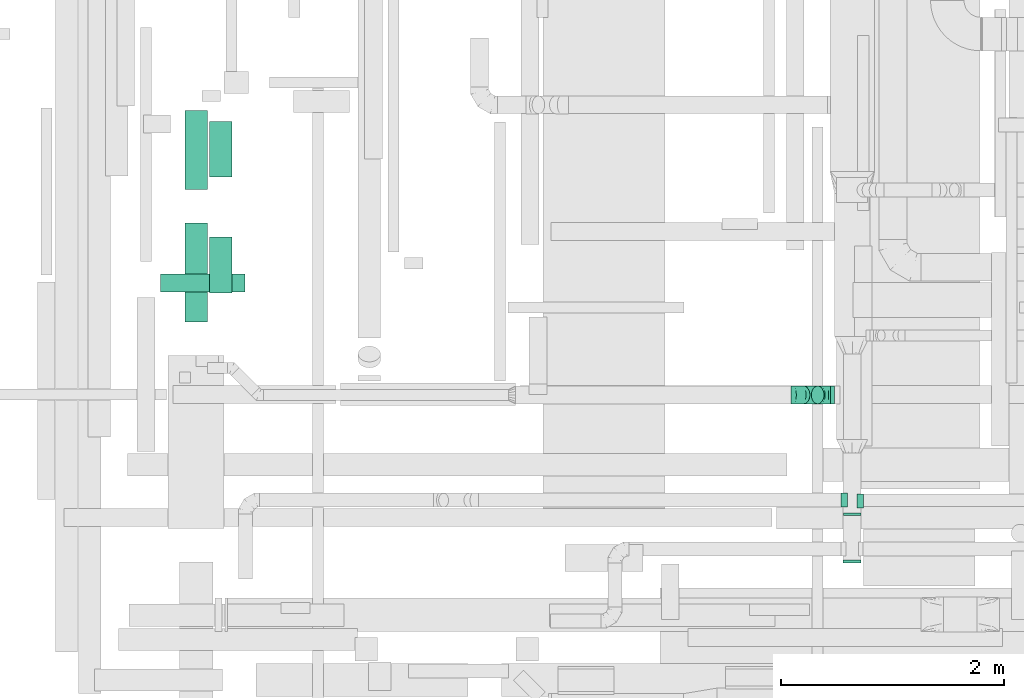
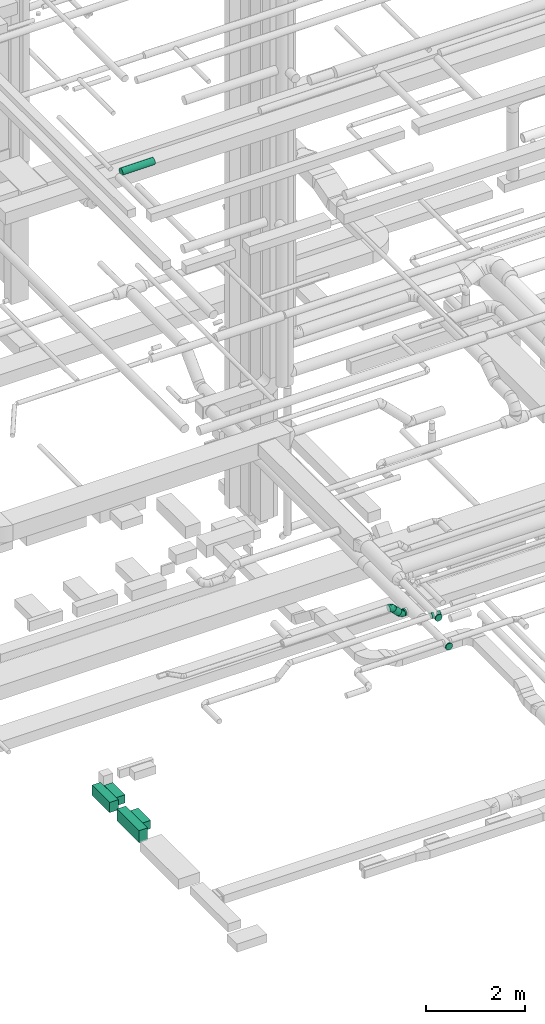
# One storey, part 117 of 337: 7 flow segments, 6 flow fittings.
"""IFC2X3 building model written with IfcOpenShell, lengths in millimetres."""

from ifc_helpers import new_model, entity, si_unit, converted_unit, derived_unit, direction, frame, origin, origin_2d_with_axis, place, context, subcontext, project, spatial, rectangle, circle, extrude, faceted_brep, source, transform, mapped, material, type_object, type_shapes, element, save


model = new_model("IFC2X3")

# Units and contexts
model_context = context("Model", 3, precision=0.01, world=origin(), true_north=direction((6.12303176911189e-17, 1.0)))
body_context = subcontext(model_context, "Body", "Model", "MODEL_VIEW")
ifc_project = project(units=[si_unit("LENGTHUNIT", "METRE", prefix="MILLI"), si_unit("AREAUNIT", "SQUARE_METRE"), si_unit("VOLUMEUNIT", "CUBIC_METRE"), converted_unit("PLANEANGLEUNIT", "DEGREE", entity("IfcRatioMeasure", 0.0174532925199433), si_unit("PLANEANGLEUNIT", "RADIAN"), dimensions=[0, 0, 0, 0, 0, 0, 0]), si_unit("MASSUNIT", "GRAM", prefix="KILO"), derived_unit("MASSDENSITYUNIT", [(si_unit("MASSUNIT", "GRAM", prefix="KILO"), 1), (si_unit("LENGTHUNIT", "METRE"), -3)]), derived_unit("MOMENTOFINERTIAUNIT", [(si_unit("LENGTHUNIT", "METRE"), 4)]), si_unit("TIMEUNIT", "SECOND"), si_unit("FREQUENCYUNIT", "HERTZ"), si_unit("THERMODYNAMICTEMPERATUREUNIT", "DEGREE_CELSIUS"), derived_unit("THERMALTRANSMITTANCEUNIT", [(si_unit("MASSUNIT", "GRAM", prefix="KILO"), 1), (si_unit("THERMODYNAMICTEMPERATUREUNIT", "KELVIN"), -1), (si_unit("TIMEUNIT", "SECOND"), -3)]), derived_unit("VOLUMETRICFLOWRATEUNIT", [(si_unit("LENGTHUNIT", "METRE"), 3), (si_unit("TIMEUNIT", "SECOND"), -1)]), derived_unit("MASSFLOWRATEUNIT", [(si_unit("MASSUNIT", "GRAM", prefix="KILO"), 1), (si_unit("TIMEUNIT", "SECOND"), -1)]), derived_unit("ROTATIONALFREQUENCYUNIT", [(si_unit("TIMEUNIT", "SECOND"), -1)]), si_unit("ELECTRICCURRENTUNIT", "AMPERE"), si_unit("ELECTRICVOLTAGEUNIT", "VOLT"), si_unit("POWERUNIT", "WATT"), si_unit("FORCEUNIT", "NEWTON", prefix="KILO"), si_unit("ILLUMINANCEUNIT", "LUX"), si_unit("LUMINOUSFLUXUNIT", "LUMEN"), si_unit("LUMINOUSINTENSITYUNIT", "CANDELA"), derived_unit("USERDEFINED", [(si_unit("MASSUNIT", "GRAM", prefix="KILO"), -1), (si_unit("LENGTHUNIT", "METRE"), -2), (si_unit("TIMEUNIT", "SECOND"), 3), (si_unit("LUMINOUSFLUXUNIT", "LUMEN"), 1)]), derived_unit("LINEARVELOCITYUNIT", [(si_unit("LENGTHUNIT", "METRE"), 1), (si_unit("TIMEUNIT", "SECOND"), -1)]), si_unit("PRESSUREUNIT", "PASCAL"), derived_unit("USERDEFINED", [(si_unit("LENGTHUNIT", "METRE"), -2), (si_unit("MASSUNIT", "GRAM", prefix="KILO"), 1), (si_unit("TIMEUNIT", "SECOND"), -2)]), derived_unit("LINEARFORCEUNIT", [(si_unit("MASSUNIT", "GRAM", prefix="KILO"), 1), (si_unit("LENGTHUNIT", "METRE"), 1), (si_unit("TIMEUNIT", "SECOND"), -2), (si_unit("LENGTHUNIT", "METRE"), -1)]), derived_unit("PLANARFORCEUNIT", [(si_unit("MASSUNIT", "GRAM", prefix="KILO"), 1), (si_unit("LENGTHUNIT", "METRE"), 1), (si_unit("TIMEUNIT", "SECOND"), -2), (si_unit("LENGTHUNIT", "METRE"), -2)])], contexts=[model_context])

# Site, building, storey
site_placement = place(None, origin())
site = spatial("IfcSite", under=ifc_project, at=site_placement, CompositionType="ELEMENT")
building_placement = place(site_placement, origin())
building = spatial("IfcBuilding", under=site, at=building_placement, CompositionType="ELEMENT")
storey_placement = place(building_placement, origin())
storey = spatial("IfcBuildingStorey", under=building, at=storey_placement, CompositionType="ELEMENT", Elevation=0.0)

# Flow segments
duct_segment_type_1 = type_object("IfcDuctSegmentType", PredefinedType="NOTDEFINED")
flow_segment_1_placement = place(storey_placement, frame((23644.4, 5216.02, -1025.0)))
element("IfcFlowSegment", 1, at=flow_segment_1_placement, inside=storey, type_object=duct_segment_type_1, context=body_context, shape_type="SweptSolid", body=[
    extrude(rectangle(XDim=709.508080000037, YDim=200.000000000002, at=origin_2d_with_axis()), frame((100.0, 354.75, 0.0), z_axis=(0.0, 0.0, 1.0), x_axis=(0.0, 1.0, 0.0)), (0.0, 0.0, 1.0), 250.0),
])
flow_segment_2_placement = place(storey_placement, frame((23644.4, 4031.28, -1050.0)))
element("IfcFlowSegment", 2, at=flow_segment_2_placement, inside=storey, type_object=duct_segment_type_1, context=body_context, shape_type="SweptSolid", body=[
    extrude(rectangle(XDim=884.746174604839, YDim=200.000000000002, at=origin_2d_with_axis()), frame((100.0, 442.37, 0.0), z_axis=(0.0, 0.0, 1.0), x_axis=(0.0, 1.0, 0.0)), (0.0, 0.0, 1.0), 300.0),
])
flow_segment_3_placement = place(storey_placement, frame((23864.4, 4290.43, -1000.0)))
element("IfcFlowSegment", 3, at=flow_segment_3_placement, inside=storey, type_object=duct_segment_type_1, context=body_context, shape_type="SweptSolid", body=[
    extrude(rectangle(XDim=199.999999999924, YDim=500.0, at=origin_2d_with_axis()), frame((100.0, 250.0, 0.0)), (0.0, 0.0, 1.0), 200.0),
])
flow_segment_4_placement = place(storey_placement, frame((23864.4, 5327.01, -1000.0)))
element("IfcFlowSegment", 4, at=flow_segment_4_placement, inside=storey, type_object=duct_segment_type_1, context=body_context, shape_type="SweptSolid", body=[
    extrude(rectangle(XDim=200.000000000002, YDim=500.0, at=origin_2d_with_axis()), frame((100.0, 250.0, 0.0)), (0.0, 0.0, 1.0), 200.0),
])
duct_segment_type_2 = type_object("IfcDuctSegmentType", PredefinedType="NOTDEFINED")
flow_segment_5_placement = place(storey_placement, frame((23425.83, 4298.85, 15268.4)))
element("IfcFlowSegment", 5, at=flow_segment_5_placement, inside=storey, type_object=duct_segment_type_2, context=body_context, shape_type="SweptSolid", body=[
    extrude(circle(Radius=80.0, at=origin_2d_with_axis()), frame((0.0, 81.6, 81.6), z_axis=(1.0, 0.0, 0.0), x_axis=(0.0, -1.0, 0.0)), (0.0, 0.0, 1.0), 754.999999684996),
])
flow_segment_6_placement = place(storey_placement, frame((29428.82, 3294.11, 2918.4)))
element("IfcFlowSegment", 6, at=flow_segment_6_placement, inside=storey, type_object=duct_segment_type_2, context=body_context, shape_type="SweptSolid", body=[
    extrude(circle(Radius=80.0, at=origin_2d_with_axis()), frame((0.0, 81.6, 81.6), z_axis=(1.0, 0.0, 0.0), x_axis=(0.0, 1.0, 0.0)), (0.0, 0.0, 1.0), 35.4255802431832),
])
flow_segment_7_placement = place(storey_placement, frame((29131.24, 3294.11, 2988.7)))
element("IfcFlowSegment", 7, at=flow_segment_7_placement, inside=storey, type_object=duct_segment_type_2, context=body_context, shape_type="SweptSolid", body=[
    extrude(circle(Radius=80.0, at=origin_2d_with_axis()), frame((58.16, 81.6, 184.44), z_axis=(0.707106400634233, 0.0, -0.707107161738658), x_axis=(0.0, 1.0, 0.0)), (0.0, 0.0, 1.0), 178.578375436718),
])

# Flow fittings
ifc_material = material()
duct_fitting_type_1 = type_object("IfcDuctFittingType", PredefinedType="NOTDEFINED", material=ifc_material)
shared_shape_1 = source(origin(), body_context, "Body", "SweptSolid", [
    extrude(circle(Radius=79.9999999999994, at=origin_2d_with_axis()), frame((0.0, 0.0, 0.0), z_axis=(1.0, 0.0, 0.0), x_axis=(0.0, 1.0, 0.0)), (0.0, 0.0, 1.0), 25.0000000000018),
])
type_shapes(duct_fitting_type_1, [shared_shape_1])
for number, where, z_axis, x_axis in (
    (8, (29625.76, 2319.25, 3450.0), (0.0, 0.0, 1.0), (0.0, -1.0, 0.0)),
    (9, (29624.24, 1896.01, 3000.0), (0.0, 0.0, 1.0), (0.0, -1.0, 0.0)),
):
    element("IfcFlowFitting", number, at=place(storey_placement, frame(where, z_axis=z_axis, x_axis=x_axis)), inside=storey, type_object=duct_fitting_type_1, material=ifc_material, context=body_context, shape_type="MappedRepresentation", body=[
        mapped(shared_shape_1, transform((0.0, 0.0, 0.0), scale=1.0)),
    ])
duct_fitting_type_2 = type_object("IfcDuctFittingType", PredefinedType="NOTDEFINED", material=ifc_material)
shared_shape_2 = source(origin(), body_context, "Body", "Brep", [
    faceted_brep([(20.0, 16.18, -60.37), (20.0, 31.25, -54.13), (20.0, 44.19, -44.19), (20.0, 54.13, -31.25), (20.0, 60.37, -16.18), (20.0, 62.5, 0.0), (20.0, 60.37, 16.18), (20.0, 54.13, 31.25), (20.0, 44.19, 44.19), (20.0, 31.25, 54.13), (20.0, 16.18, 60.37), (20.0, 0.0, 62.5), (20.0, -16.18, 60.37), (20.0, -31.25, 54.13), (20.0, -44.19, 44.19), (20.0, -54.13, 31.25), (20.0, -60.37, 16.18), (20.0, -62.5, 0.0), (20.0, -60.37, -16.18), (20.0, -54.13, -31.25), (20.0, -44.19, -44.19), (20.0, -31.25, -54.13), (20.0, -16.18, -60.37), (20.0, 0.0, -62.5), (0.0, 0.0, 62.5), (0.0, 16.18, 60.37), (-36.16, 16.18, 60.37), (-36.16, 0.0, 62.5), (0.0, 31.25, 54.13), (-36.16, 31.25, 54.13), (0.0, 44.19, 44.19), (-36.16, 44.19, 44.19), (0.0, 54.13, 31.25), (0.0, 60.37, 16.18), (-36.16, 60.37, 16.18), (-36.16, 54.13, 31.25), (0.0, 62.5, 0.0), (-36.16, 62.5, 0.0), (0.0, 60.37, -16.18), (-36.16, 60.37, -16.18), (0.0, 54.13, -31.25), (-36.16, 54.13, -31.25), (0.0, 44.19, -44.19), (-36.16, 44.19, -44.19), (0.0, 31.25, -54.13), (0.0, 16.18, -60.37), (-36.16, 16.18, -60.37), (-36.16, 31.25, -54.13), (0.0, 0.0, -62.5), (-36.16, 0.0, -62.5), (0.0, -16.18, -60.37), (-36.16, -16.18, -60.37), (0.0, -31.25, -54.13), (-36.16, -31.25, -54.13), (0.0, -44.19, -44.19), (-36.16, -44.19, -44.19), (0.0, -54.13, -31.25), (0.0, -60.37, -16.18), (-36.16, -60.37, -16.18), (-36.16, -54.13, -31.25), (0.0, -62.5, 0.0), (-36.16, -62.5, 0.0), (0.0, -60.37, 16.18), (-36.16, -60.37, 16.18), (0.0, -54.13, 31.25), (-36.16, -54.13, 31.25), (0.0, -44.19, 44.19), (-36.16, -44.19, 44.19), (0.0, -31.25, 54.13), (0.0, -16.18, 60.37), (-36.16, -16.18, 60.37), (-36.16, -31.25, 54.13)], [[[0, 1, 2, 3, 4, 5, 6, 7, 8, 9, 10, 11, 12, 13, 14, 15, 16, 17, 18, 19, 20, 21, 22, 23]], [[24, 11, 10, 25, 26, 27]], [[25, 10, 9, 28, 29, 26]], [[28, 9, 8, 30, 31, 29]], [[32, 7, 6, 33, 34, 35]], [[33, 6, 5, 36, 37, 34]], [[30, 8, 7, 32, 35, 31]], [[36, 5, 4, 38, 39, 37]], [[38, 4, 3, 40, 41, 39]], [[40, 3, 2, 42, 43, 41]], [[44, 1, 0, 45, 46, 47]], [[45, 0, 23, 48, 49, 46]], [[42, 2, 1, 44, 47, 43]], [[48, 23, 22, 50, 51, 49]], [[50, 22, 21, 52, 53, 51]], [[52, 21, 20, 54, 55, 53]], [[56, 19, 18, 57, 58, 59]], [[57, 18, 17, 60, 61, 58]], [[54, 20, 19, 56, 59, 55]], [[60, 17, 16, 62, 63, 61]], [[62, 16, 15, 64, 65, 63]], [[64, 15, 14, 66, 67, 65]], [[68, 13, 12, 69, 70, 71]], [[69, 12, 11, 24, 27, 70]], [[66, 14, 13, 68, 71, 67]], [[49, 51, 53, 55, 59, 58, 61, 63, 65, 67, 71, 70, 27, 26, 29, 31, 35, 34, 37, 39, 41, 43, 47, 46]]]),
])
type_shapes(duct_fitting_type_2, [shared_shape_2])
flow_fitting_1_placement = place(storey_placement, frame((29545.76, 2432.13, 3450.0), z_axis=(0.0, 0.0, -1.0), x_axis=(-1.0, 0.0, 0.0)))
element("IfcFlowFitting", 10, at=flow_fitting_1_placement, inside=storey, type_object=duct_fitting_type_2, material=ifc_material, context=body_context, shape_type="MappedRepresentation", body=[
    mapped(shared_shape_2, transform((0.0, 0.0, 0.0), scale=1.0)),
])
duct_fitting_type_3 = type_object("IfcDuctFittingType", PredefinedType="NOTDEFINED", material=ifc_material)
shared_shape_3 = source(origin(), body_context, "Body", "Brep", [
    faceted_brep([(20.0, 0.0, -62.5), (20.0, 16.18, -60.37), (20.0, 31.25, -54.13), (20.0, 44.19, -44.19), (20.0, 54.13, -31.25), (20.0, 60.37, -16.18), (20.0, 62.5, 0.0), (20.0, 60.37, 16.18), (20.0, 54.13, 31.25), (20.0, 44.19, 44.19), (20.0, 31.25, 54.13), (20.0, 16.18, 60.37), (20.0, 0.0, 62.5), (20.0, -16.18, 60.37), (20.0, -31.25, 54.13), (20.0, -44.19, 44.19), (20.0, -54.13, 31.25), (20.0, -60.37, 16.18), (20.0, -62.5, 0.0), (20.0, -60.37, -16.18), (20.0, -54.13, -31.25), (20.0, -44.19, -44.19), (20.0, -31.25, -54.13), (20.0, -16.18, -60.37), (0.0, 0.0, 62.5), (-36.16, 0.0, 62.5), (-36.16, -16.18, 60.37), (0.0, -16.18, 60.37), (-36.16, -31.25, 54.13), (0.0, -31.25, 54.13), (0.0, -44.19, 44.19), (-36.16, -44.19, 44.19), (0.0, -54.13, 31.25), (-36.16, -54.13, 31.25), (-36.16, -60.37, 16.18), (0.0, -60.37, 16.18), (-36.16, -62.5, 0.0), (0.0, -62.5, 0.0), (-36.16, -60.37, -16.18), (0.0, -60.37, -16.18), (-36.16, -54.13, -31.25), (0.0, -54.13, -31.25), (0.0, -44.19, -44.19), (-36.16, -44.19, -44.19), (0.0, -31.25, -54.13), (-36.16, -31.25, -54.13), (-36.16, -16.18, -60.37), (0.0, -16.18, -60.37), (-36.16, 0.0, -62.5), (0.0, 0.0, -62.5), (-36.16, 16.18, -60.37), (0.0, 16.18, -60.37), (-36.16, 31.25, -54.13), (0.0, 31.25, -54.13), (0.0, 44.19, -44.19), (-36.16, 44.19, -44.19), (0.0, 54.13, -31.25), (-36.16, 54.13, -31.25), (-36.16, 60.37, -16.18), (0.0, 60.37, -16.18), (-36.16, 62.5, 0.0), (0.0, 62.5, 0.0), (-36.16, 60.37, 16.18), (0.0, 60.37, 16.18), (-36.16, 54.13, 31.25), (0.0, 54.13, 31.25), (0.0, 44.19, 44.19), (-36.16, 44.19, 44.19), (0.0, 31.25, 54.13), (-36.16, 31.25, 54.13), (-36.16, 16.18, 60.37), (0.0, 16.18, 60.37)], [[[0, 1, 2, 3, 4, 5, 6, 7, 8, 9, 10, 11, 12, 13, 14, 15, 16, 17, 18, 19, 20, 21, 22, 23]], [[13, 12, 24, 25, 26, 27]], [[14, 13, 27, 26, 28, 29]], [[30, 15, 14, 29, 28, 31]], [[17, 16, 32, 33, 34, 35]], [[18, 17, 35, 34, 36, 37]], [[32, 16, 15, 30, 31, 33]], [[19, 18, 37, 36, 38, 39]], [[20, 19, 39, 38, 40, 41]], [[42, 21, 20, 41, 40, 43]], [[23, 22, 44, 45, 46, 47]], [[0, 23, 47, 46, 48, 49]], [[44, 22, 21, 42, 43, 45]], [[1, 0, 49, 48, 50, 51]], [[2, 1, 51, 50, 52, 53]], [[54, 3, 2, 53, 52, 55]], [[5, 4, 56, 57, 58, 59]], [[6, 5, 59, 58, 60, 61]], [[56, 4, 3, 54, 55, 57]], [[7, 6, 61, 60, 62, 63]], [[8, 7, 63, 62, 64, 65]], [[66, 9, 8, 65, 64, 67]], [[11, 10, 68, 69, 70, 71]], [[12, 11, 71, 70, 25, 24]], [[68, 10, 9, 66, 67, 69]], [[46, 45, 43, 40, 38, 36, 34, 33, 31, 28, 26, 25, 70, 69, 67, 64, 62, 60, 58, 57, 55, 52, 50, 48]]]),
])
type_shapes(duct_fitting_type_3, [shared_shape_3])
flow_fitting_2_placement = place(storey_placement, frame((29705.76, 2424.63, 3450.0), z_axis=(0.0, 0.0, -1.0), x_axis=(1.0, 0.0, 0.0)))
element("IfcFlowFitting", 11, at=flow_fitting_2_placement, inside=storey, type_object=duct_fitting_type_3, material=ifc_material, context=body_context, shape_type="MappedRepresentation", body=[
    mapped(shared_shape_3, transform((0.0, 0.0, 0.0), scale=1.0)),
])
duct_fitting_type_4 = type_object("IfcDuctFittingType", PredefinedType="NOTDEFINED", material=ifc_material)
shared_shape_4 = source(origin(), body_context, "Body", "Brep", [
    faceted_brep([(-66.27, 0.0, -80.0), (-66.27, -20.71, -77.27), (-66.27, -40.0, -69.28), (-66.27, -56.57, -56.57), (-66.27, -69.28, -40.0), (-66.27, -77.27, -20.71), (-66.27, -80.0, 0.0), (-66.27, -77.27, 20.71), (-66.27, -69.28, 40.0), (-66.27, -56.57, 56.57), (-66.27, -40.0, 69.28), (-66.27, -20.71, 77.27), (-66.27, 0.0, 80.0), (-66.27, 20.71, 77.27), (-66.27, 40.0, 69.28), (-66.27, 56.57, 56.57), (-66.27, 69.28, 40.0), (-66.27, 77.27, 20.71), (-66.27, 80.0, 0.0), (-66.27, 77.27, -20.71), (-66.27, 69.28, -40.0), (-66.27, 56.57, -56.57), (-66.27, 40.0, -69.28), (-66.27, 20.71, -77.27), (-38.57, 20.71, 77.27), (-42.4, 40.0, 69.28), (-34.45, 0.0, 80.0), (-45.7, 56.57, 56.57), (-49.82, 77.27, 20.71), (-50.36, 80.0, 0.0), (-48.23, 69.28, 40.0), (-48.23, 69.28, -40.0), (-45.7, 56.57, -56.57), (-49.82, 77.27, -20.71), (-38.57, 20.71, -77.27), (-34.45, 0.0, -80.0), (-42.4, 40.0, -69.28), (-30.33, -20.71, -77.27), (-26.49, -40.0, -69.28), (-23.2, -56.57, -56.57), (-20.67, -69.28, -40.0), (-19.08, -77.27, -20.71), (-18.54, -80.0, 0.0), (-19.08, -77.27, 20.71), (-20.67, -69.28, 40.0), (-23.2, -56.57, 56.57), (-26.49, -40.0, 69.28), (-30.33, -20.71, 77.27), (12.63, 41.91, 77.27), (1.7, 58.27, 69.28), (24.36, 24.36, 80.0), (-7.68, 72.32, 56.57), (-14.89, 83.09, 40.0), (-19.41, 89.87, 20.71), (-20.96, 92.18, 0.0), (-19.41, 89.87, -20.71), (-14.89, 83.09, -40.0), (-7.68, 72.32, -56.57), (12.63, 41.91, -77.27), (24.36, 24.36, -80.0), (1.7, 58.27, -69.28), (36.09, 6.81, -77.27), (47.02, -9.55, -69.28), (56.4, -23.6, -56.57), (63.6, -34.38, -40.0), (68.13, -41.15, -20.71), (69.67, -43.46, 0.0), (68.13, -41.15, 20.71), (63.6, -34.38, 40.0), (56.4, -23.6, 56.57), (47.02, -9.55, 69.28), (36.09, 6.81, 77.27), (46.86, 46.86, 80.0), (32.22, 61.5, 77.27), (18.58, 75.15, 69.28), (6.86, 86.86, 56.57), (-2.13, 95.85, 40.0), (-7.78, 101.5, 20.71), (-9.71, 103.43, 0.0), (-7.78, 101.5, -20.71), (-2.13, 95.85, -40.0), (6.86, 86.86, -56.57), (18.58, 75.15, -69.28), (32.22, 61.5, -77.27), (46.86, 46.86, -80.0), (61.5, 32.22, -77.27), (75.15, 18.58, -69.28), (86.86, 6.86, -56.57), (101.5, -7.78, -20.71), (103.43, -9.71, 0.0), (95.85, -2.13, -40.0), (101.5, -7.78, 20.71), (95.85, -2.13, 40.0), (86.86, 6.86, 56.57), (61.5, 32.22, 77.27), (75.15, 18.58, 69.28)], [[[0, 1, 2, 3, 4, 5, 6, 7, 8, 9, 10, 11, 12, 13, 14, 15, 16, 17, 18, 19, 20, 21, 22, 23]], [[24, 25, 14, 13]], [[26, 24, 13, 12]], [[14, 25, 27, 15]], [[28, 29, 18, 17]], [[30, 28, 17, 16]], [[15, 27, 30, 16]], [[20, 31, 32, 21]], [[33, 31, 20, 19]], [[18, 29, 33, 19]], [[34, 35, 0, 23]], [[36, 34, 23, 22]], [[32, 36, 22, 21]], [[2, 1, 37, 38]], [[3, 2, 38, 39]], [[0, 35, 37, 1]], [[5, 4, 40, 41]], [[6, 5, 41, 42]], [[3, 39, 40, 4]], [[6, 42, 43, 7]], [[7, 43, 44, 8]], [[8, 44, 45, 9]], [[10, 46, 47, 11]], [[11, 47, 26, 12]], [[9, 45, 46, 10]], [[48, 49, 25, 24]], [[50, 48, 24, 26]], [[27, 25, 49, 51]], [[52, 53, 28, 30]], [[51, 52, 30, 27]], [[29, 28, 53, 54]], [[55, 56, 31, 33]], [[54, 55, 33, 29]], [[32, 31, 56, 57]], [[58, 59, 35, 34]], [[60, 58, 34, 36]], [[57, 60, 36, 32]], [[37, 35, 59, 61]], [[38, 37, 61, 62]], [[39, 38, 62, 63]], [[41, 40, 64, 65]], [[42, 41, 65, 66]], [[63, 64, 40, 39]], [[43, 42, 66, 67]], [[44, 43, 67, 68]], [[68, 69, 45, 44]], [[46, 45, 69, 70]], [[47, 46, 70, 71]], [[26, 47, 71, 50]], [[48, 50, 72, 73]], [[49, 48, 73, 74]], [[51, 49, 74, 75]], [[53, 52, 76, 77]], [[54, 53, 77, 78]], [[51, 75, 76, 52]], [[54, 78, 79, 55]], [[55, 79, 80, 56]], [[56, 80, 81, 57]], [[60, 82, 83, 58]], [[58, 83, 84, 59]], [[60, 57, 81, 82]], [[59, 84, 85, 61]], [[61, 85, 86, 62]], [[62, 86, 87, 63]], [[88, 89, 66, 65]], [[90, 88, 65, 64]], [[63, 87, 90, 64]], [[67, 66, 89, 91]], [[68, 67, 91, 92]], [[69, 68, 92, 93]], [[94, 72, 50, 71]], [[95, 94, 71, 70]], [[93, 95, 70, 69]], [[83, 82, 81, 80, 79, 78, 77, 76, 75, 74, 73, 72, 94, 95, 93, 92, 91, 89, 88, 90, 87, 86, 85, 84]]]),
])
type_shapes(duct_fitting_type_4, [shared_shape_4])
for number, where, z_axis, x_axis in (
    (12, (29362.54, 3375.7, 3000.0), (0.0, 1.0, 0.0), (-1.0, 0.0, 0.0)),
    (13, (29142.54, 3375.7, 3220.0), (0.0, -1.0, 0.0), (-0.707106400634175, 0.0, 0.707107161738715)),
):
    element("IfcFlowFitting", number, at=place(storey_placement, frame(where, z_axis=z_axis, x_axis=x_axis)), inside=storey, type_object=duct_fitting_type_4, material=ifc_material, context=body_context, shape_type="MappedRepresentation", body=[
        mapped(shared_shape_4, transform((0.0, 0.0, 0.0), scale=1.0)),
    ])

save(model, "model.ifc")
